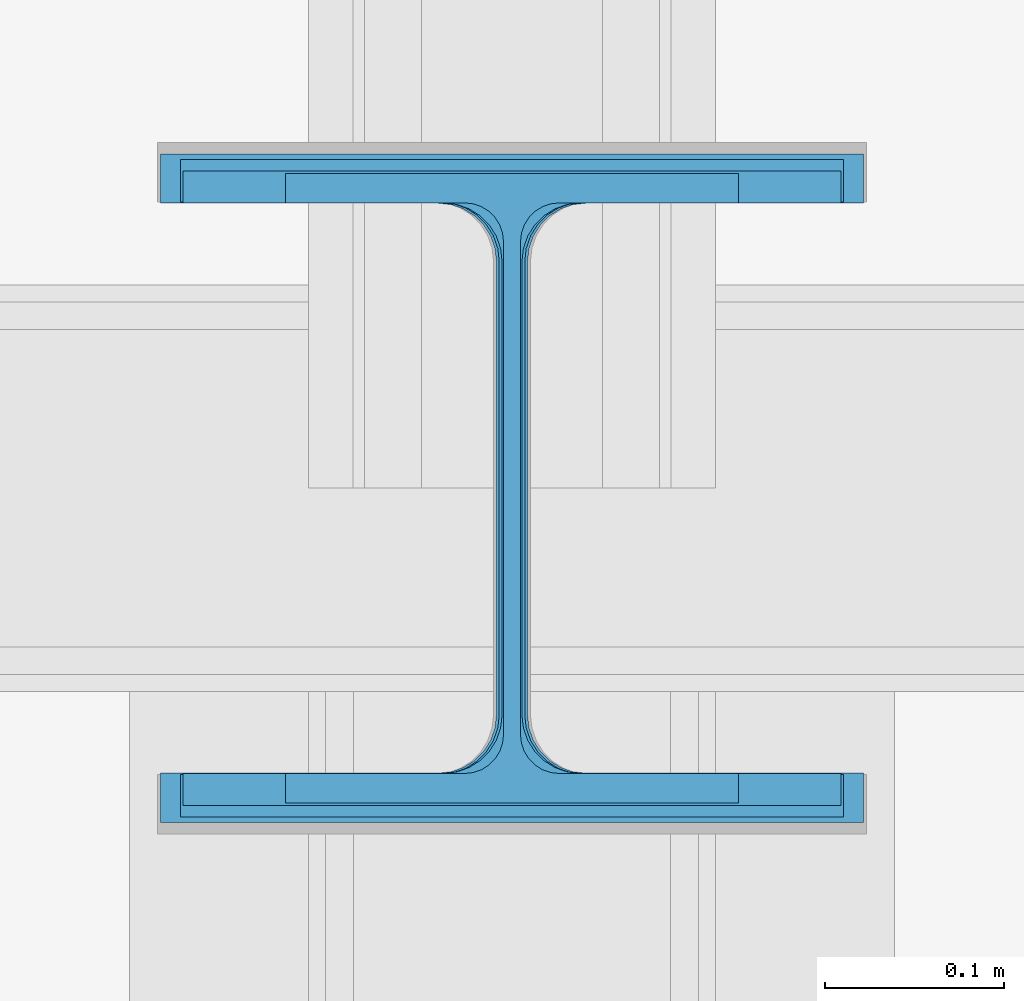
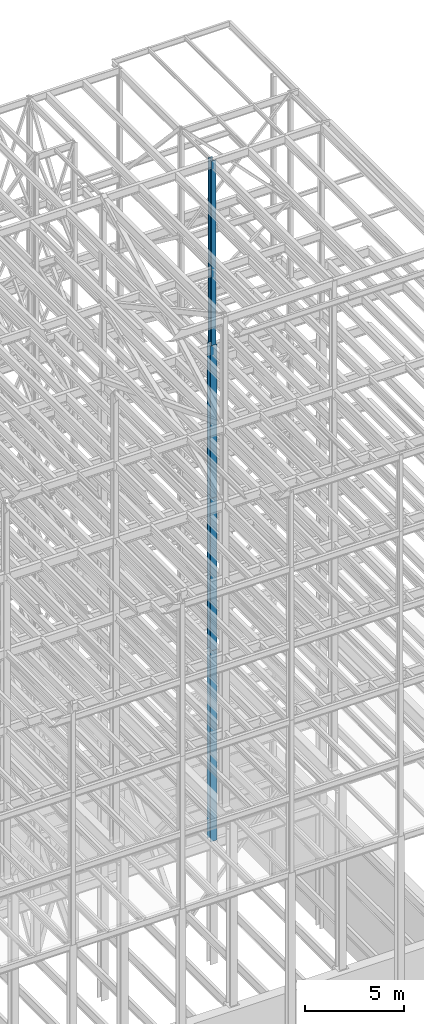
# One storey, part 110 of 150: 4 columns.
"""IFC2X3 building model written with IfcOpenShell, lengths in millimetres."""

from ifc_helpers import new_model, si_unit, frame, origin_with_axes, origin_2d_with_axis, place, context, subcontext, project, spatial, i_section, extrude, material, type_object, element, save


model = new_model("IFC2X3")

# Units and contexts
model_context = context("Model", 3, precision=1e-05, world=origin_with_axes())
body_context = subcontext(model_context, "Body", "Model", "MODEL_VIEW")
ifc_project = project(units=[si_unit("LENGTHUNIT", "METRE", prefix="MILLI"), si_unit("AREAUNIT", "SQUARE_METRE"), si_unit("VOLUMEUNIT", "CUBIC_METRE"), si_unit("MASSUNIT", "GRAM", prefix="KILO"), si_unit("TIMEUNIT", "SECOND"), si_unit("PLANEANGLEUNIT", "RADIAN"), si_unit("SOLIDANGLEUNIT", "STERADIAN"), si_unit("THERMODYNAMICTEMPERATUREUNIT", "DEGREE_CELSIUS"), si_unit("LUMINOUSINTENSITYUNIT", "LUMEN")], contexts=[model_context])

# Site, building, storey
site_placement = place(None, origin_with_axes())
site = spatial("IfcSite", under=ifc_project, at=site_placement, CompositionType="ELEMENT")
building_placement = place(site_placement, origin_with_axes())
building = spatial("IfcBuilding", under=site, at=building_placement, Name="Undefined", CompositionType="ELEMENT")
storey_placement = place(building_placement, origin_with_axes())
storey = spatial("IfcBuildingStorey", under=building, at=storey_placement, Name="Undefined", CompositionType="ELEMENT", Elevation=0.0)

# Columns
ifc_material = material(Name="STEEL/A992")
column_type_1 = type_object("IfcColumnType", Name="W14X61", PredefinedType="NOTDEFINED")
column_1_placement = place(storey_placement, frame((82194.4, 22479.0, 54483.0), z_axis=(0.0, 0.0, 1.0), x_axis=(1.0, 0.0, 0.0)))
element("IfcColumn", 1, at=column_1_placement, inside=storey, type_object=column_type_1, material=ifc_material, Name="COLUMN", ObjectType="W14X61", context=body_context, shape_type="SweptSolid", body=[
    extrude(i_section(OverallWidth=254.0, OverallDepth=352.425, WebThickness=9.5249, FlangeThickness=16.383, FilletRadius=21.717, at=origin_2d_with_axis()), frame((0.0, 0.0, 11430.0), z_axis=(0.0, 0.0, -1.0), x_axis=(-1.0, 0.0, 0.0)), (0.0, 0.0, 1.0), 11430.0),
])
column_type_2 = type_object("IfcColumnType", Name="W14X90", PredefinedType="NOTDEFINED")
column_2_placement = place(storey_placement, frame((82194.4, 22479.0, 45034.2), z_axis=(0.0, 0.0, 1.0), x_axis=(1.0, 0.0, 0.0)))
element("IfcColumn", 2, at=column_2_placement, inside=storey, type_object=column_type_2, material=ifc_material, Name="COLUMN", ObjectType="W14X90", context=body_context, shape_type="SweptSolid", body=[
    extrude(i_section(OverallWidth=368.3, OverallDepth=355.6, WebThickness=11.1125, FlangeThickness=18.034, FilletRadius=32.7659, at=origin_2d_with_axis()), frame((0.0, 0.0, 9448.8), z_axis=(0.0, 0.0, -1.0), x_axis=(-1.0, 0.0, 0.0)), (0.0, 0.0, 1.0), 9448.8),
])
column_type_3 = type_object("IfcColumnType", Name="W14X145", PredefinedType="NOTDEFINED")
column_3_placement = place(storey_placement, frame((82194.4, 22479.0, 23774.4), z_axis=(0.0, 0.0, 1.0), x_axis=(1.0, 0.0, 0.0)))
element("IfcColumn", 3, at=column_3_placement, inside=storey, type_object=column_type_3, material=ifc_material, Name="COLUMN", ObjectType="W14X145", context=body_context, shape_type="SweptSolid", body=[
    extrude(i_section(OverallWidth=393.7, OverallDepth=374.65, WebThickness=17.4625, FlangeThickness=27.686, FilletRadius=32.6389, at=origin_2d_with_axis()), frame((0.0, 0.0, 11811.0), z_axis=(0.0, 0.0, -1.0), x_axis=(-1.0, 0.0, 0.0)), (0.0, 0.0, 1.0), 11811.0),
])
column_type_4 = type_object("IfcColumnType", Name="W14X120", PredefinedType="NOTDEFINED")
column_4_placement = place(storey_placement, frame((82194.4, 22479.0, 35585.4), z_axis=(0.0, 0.0, 1.0), x_axis=(1.0, 0.0, 0.0)))
element("IfcColumn", 4, at=column_4_placement, inside=storey, type_object=column_type_4, material=ifc_material, Name="COLUMN", ObjectType="W14X120", context=body_context, shape_type="SweptSolid", body=[
    extrude(i_section(OverallWidth=371.475, OverallDepth=368.3, WebThickness=14.2875, FlangeThickness=23.876, FilletRadius=33.274, at=origin_2d_with_axis()), frame((0.0, 0.0, 9448.8), z_axis=(0.0, 0.0, -1.0), x_axis=(-1.0, 0.0, 0.0)), (0.0, 0.0, 1.0), 9448.79999999999),
])

save(model, "model.ifc")
